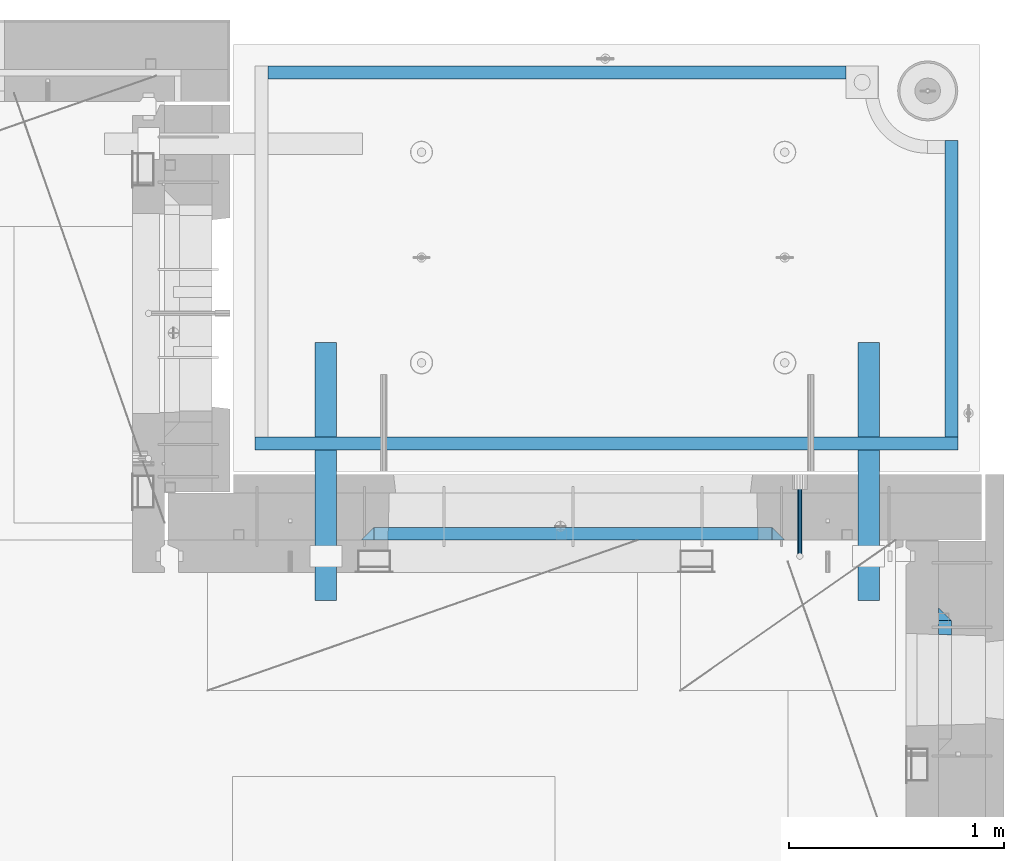
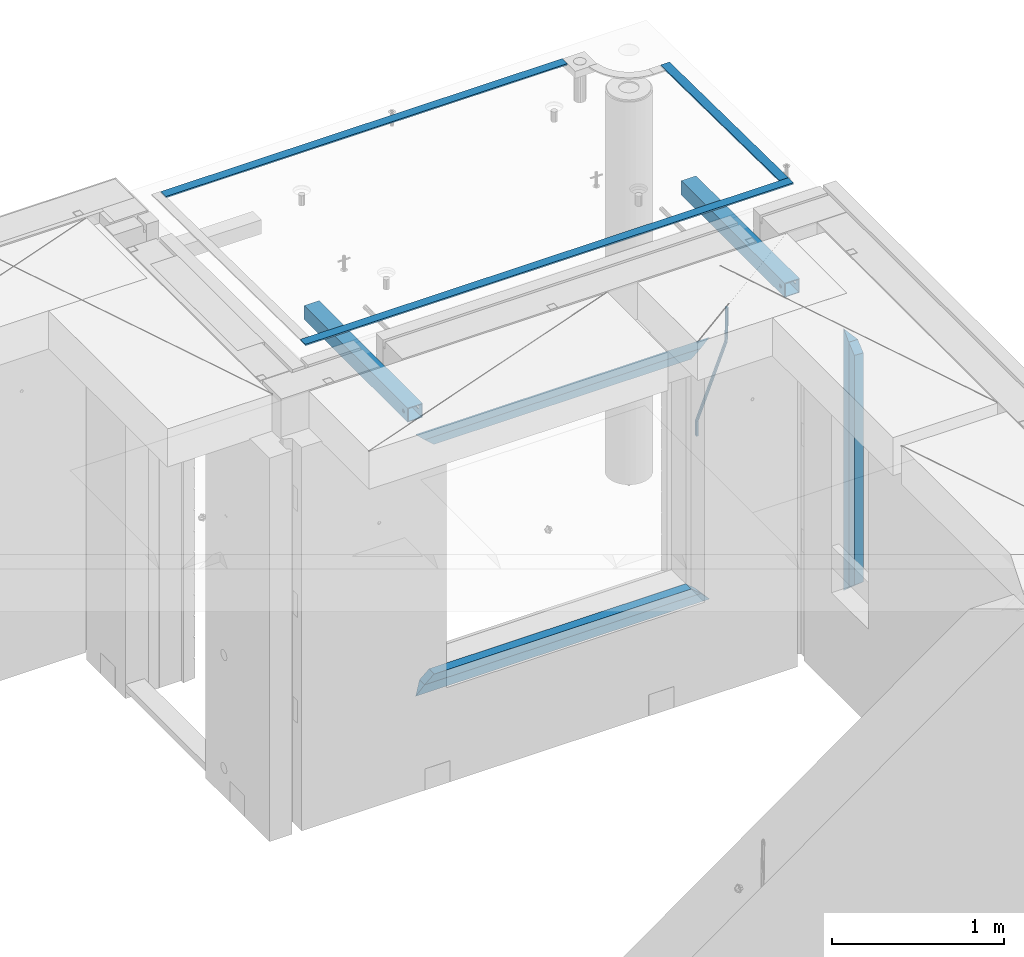
# One storey, part 128 of 334: 12 beams, 5 elements without a shape of their own.
"""IFC2X3 building model written with IfcOpenShell, lengths in millimetres."""

from ifc_helpers import new_model, si_unit, frame, origin_with_axes, place, context, subcontext, project, spatial, faceted_brep, material, type_object, element, aggregate, save


model = new_model("IFC2X3")

# Units and contexts
model_context = context("Model", 3, precision=1e-05, world=origin_with_axes())
body_context = subcontext(model_context, "Body", "Model", "MODEL_VIEW")
ifc_project = project(units=[si_unit("LENGTHUNIT", "METRE", prefix="MILLI"), si_unit("AREAUNIT", "SQUARE_METRE"), si_unit("VOLUMEUNIT", "CUBIC_METRE"), si_unit("MASSUNIT", "GRAM", prefix="KILO"), si_unit("TIMEUNIT", "SECOND"), si_unit("PLANEANGLEUNIT", "RADIAN"), si_unit("SOLIDANGLEUNIT", "STERADIAN"), si_unit("THERMODYNAMICTEMPERATUREUNIT", "DEGREE_CELSIUS"), si_unit("LUMINOUSINTENSITYUNIT", "LUMEN")], contexts=[model_context])

# Site, building, storey
site_placement = place(None, origin_with_axes())
site = spatial("IfcSite", under=ifc_project, at=site_placement, CompositionType="ELEMENT")
building_placement = place(site_placement, origin_with_axes())
building = spatial("IfcBuilding", under=site, at=building_placement, CompositionType="ELEMENT")
storey_placement = place(building_placement, origin_with_axes())
storey = spatial("IfcBuildingStorey", under=building, at=storey_placement, Name="3", CompositionType="ELEMENT", Elevation=0.0)

# Assembly, beam
assembly_1_placement = place(storey_placement, origin_with_axes())
assembly_1 = element("IfcElementAssembly", 1, at=assembly_1_placement, inside=storey, AssemblyPlace="NOTDEFINED", PredefinedType="REINFORCEMENT_UNIT")
ifc_material_1 = material()
beam_type_1 = type_object("IfcBeamType", Name="D20", PredefinedType="NOTDEFINED")
beam_1_placement = place(assembly_1_placement, frame((34415.0000001015, 20504.9951872346, 90407.5), z_axis=(0.000415599999849905, 0.999999913638203, 4.76000000899737e-07), x_axis=(0.0, 0.0, -1.0)))
beam_1 = element("IfcBeam", 2, at=beam_1_placement, type_object=beam_type_1, material=ifc_material_1, Name="JM20", ObjectType="D20", context=body_context, shape_type="Brep", body=[
    faceted_brep([(-0.00060564729210455, -9.99999998165731, 0.0), (-0.000428079845733009, -7.07106779890455, -7.07106781186667), (119.575515501536, -7.07830994756296, -7.07106481604933), (119.575337932896, -10.0072421307195, -3.43332612828817e-06), (0.0, 0.0, -10.0), (119.575943836026, -0.00724214867295814, -9.99999700418266), (0.00042843479604926, 7.07106779888636, -7.07106781186303), (119.57637202373, 7.06382565022977, -7.07106481604933), (0.00060564729210455, 9.99999998166459, 3.63797880709171e-12), (119.576549238118, 9.99275783300072, 2.99581552098971e-06), (0.000428079845733009, 7.07106779890819, 7.07106781186667), (119.576371669405, 7.06382565024978, 7.07107080768037), (0.0, 0.0, 10.0), (119.57594333493, -0.00724214864203532, 10.0000029958155), (-0.000428434810601175, -7.07106779888272, 7.07106781186667), (119.575515147211, -7.07830994754295, 7.07107080768037), (123.00654325854, -7.07836650239551, -6.96786008391246), (122.581588830741, -10.007295666459, 0.0904344953341933), (123.182419066041, -0.00729994480025198, -9.89151006310021), (123.006190977103, 7.06376911688858, -6.96788735351402), (122.581091016109, 9.99270432680532, 0.0903895128230943), (122.156136974867, 7.06377516229986, 7.14867767459873), (121.980261167351, -0.00729139528993983, 10.0723276537792), (122.156489256289, -7.07836045697513, 7.14870494419847), (237.077376207715, -7.07551629289992, -0.0988779924864502), (236.652422053201, -10.0044409119728, 6.95941204931296), (237.253252288647, -0.0044516184279928, -3.02253250974718), (237.077024472936, 7.06661932641327, -0.0989143382521434), (236.651924624995, 9.99555908263574, 6.95936064834314), (236.226970470365, 7.06663446442326, 14.0176506898479), (236.051094389448, -0.0044302100486675, 16.9413052071086), (236.227322205144, -7.07550115488812, 14.0176870356117), (256.715938387759, -7.07353516174771, 4.66794781703175), (253.858321224223, -10.0027051854922, 11.1357628166734), (257.898622435067, -0.00236892073007766, 1.98867362452802), (256.713573090979, 7.0686002544353, 4.66742272414376), (253.85497618909, 9.99729452004976, 11.1350202234971), (250.997359025234, 7.06812449537756, 17.6028352234607), (249.814674977912, -0.00304174564189452, 20.2821094159572), (250.999724322028, -7.07401092080545, 17.6033603163596), (1009.84102825288, -6.93521658215468, 337.477148757798), (1006.98341108896, -9.86438660663771, 343.944963757851), (1011.02371230032, 0.135949658781101, 334.7978745651), (1009.83866295629, 7.20691883402651, 337.476623664521), (1006.98006605446, 10.1356130998429, 343.944221163818), (1004.12244889054, 7.2064430753635, 350.412036163872), (1002.9397648431, 0.135276834424076, 353.091310356571), (1004.12481418712, -6.93569234081951, 350.412561257146), (1010.86335274603, -6.9350288225487, 337.928918327354), (1009.37086865908, -9.86394812736762, 344.999991477531), (1011.48104818776, 0.136033652863262, 334.999973251377), (1010.86211737194, 7.20710680115553, 337.928892551665), (1009.36912157628, 10.1360518725905, 344.9999550252), (1007.87663748935, 7.2071325677698, 352.071028175378), (1007.2589420476, 0.13607009235966, 354.999973251352), (1007.87787286344, -6.93500305593261, 352.071053951067), (1011.98104820926, -6.93502881915083, 337.92891832735), (1011.98104821818, -9.86394811943501, 344.999991477524), (1011.98104818776, 0.136033654382118, 334.999973251375), (1011.98104816627, 7.20710680455704, 337.928892551661), (1011.98104815738, 10.1360518805304, 344.999955025194), (1011.98104816629, 7.20713258024625, 352.071028175369), (1011.98104818778, 0.136070106711486, 354.999973251342), (1011.98104820927, -6.9350030434598, 352.071053951058), (1117.50000002154, -6.93502849844299, 337.928918327156), (1117.50000003044, -9.86394779872717, 344.999991477331), (1117.50000000004, 0.136033975091777, 334.999973251181), (1117.49999997855, 7.20710712526488, 337.928892551467), (1117.49999996964, 10.1360522012383, 344.999955025), (1117.49999997857, 7.20713290095409, 352.071028175174), (1117.50000000006, 0.136070427419327, 354.999973251148), (1117.50000002155, -6.93500272275196, 352.071053950864)], [[[0, 1, 2, 3]], [[1, 4, 5, 2]], [[4, 6, 7, 5]], [[6, 8, 9, 7]], [[8, 10, 11, 9]], [[10, 12, 13, 11]], [[12, 14, 15, 13]], [[14, 0, 3, 15]], [[14, 12, 10, 8, 6, 4, 1, 0]], [[3, 2, 16, 17]], [[2, 5, 18, 16]], [[5, 7, 19, 18]], [[7, 9, 20, 19]], [[9, 11, 21, 20]], [[11, 13, 22, 21]], [[13, 15, 23, 22]], [[15, 3, 17, 23]], [[17, 16, 24, 25]], [[16, 18, 26, 24]], [[18, 19, 27, 26]], [[19, 20, 28, 27]], [[20, 21, 29, 28]], [[21, 22, 30, 29]], [[22, 23, 31, 30]], [[23, 17, 25, 31]], [[25, 24, 32, 33]], [[24, 26, 34, 32]], [[26, 27, 35, 34]], [[27, 28, 36, 35]], [[28, 29, 37, 36]], [[29, 30, 38, 37]], [[30, 31, 39, 38]], [[31, 25, 33, 39]], [[33, 32, 40, 41]], [[32, 34, 42, 40]], [[34, 35, 43, 42]], [[35, 36, 44, 43]], [[36, 37, 45, 44]], [[37, 38, 46, 45]], [[38, 39, 47, 46]], [[39, 33, 41, 47]], [[41, 40, 48, 49]], [[40, 42, 50, 48]], [[42, 43, 51, 50]], [[43, 44, 52, 51]], [[44, 45, 53, 52]], [[45, 46, 54, 53]], [[46, 47, 55, 54]], [[47, 41, 49, 55]], [[49, 48, 56, 57]], [[48, 50, 58, 56]], [[50, 51, 59, 58]], [[51, 52, 60, 59]], [[52, 53, 61, 60]], [[53, 54, 62, 61]], [[54, 55, 63, 62]], [[55, 49, 57, 63]], [[57, 56, 64, 65]], [[56, 58, 66, 64]], [[58, 59, 67, 66]], [[59, 60, 68, 67]], [[60, 61, 69, 68]], [[61, 62, 70, 69]], [[62, 63, 71, 70]], [[63, 57, 65, 71]], [[66, 67, 68, 69, 70, 71, 65, 64]]]),
])

# Assemblies, beams
assembly_2_placement = place(storey_placement, origin_with_axes())
assembly_2 = element("IfcElementAssembly", 3, at=assembly_2_placement, inside=storey, AssemblyPlace="NOTDEFINED", PredefinedType="REINFORCEMENT_UNIT")
assembly_3_placement = place(assembly_2_placement, origin_with_axes())
assembly_3 = element("IfcElementAssembly", 4, at=assembly_3_placement, AssemblyPlace="NOTDEFINED", PredefinedType="NOTDEFINED")
ifc_material_2 = material(Name="Undefined/350")
beam_type_2 = type_object("IfcBeamType", Name="100X100X5", PredefinedType="NOTDEFINED")
beam_2_placement = place(assembly_3_placement, frame((34735.0001432011, 21500.0034426031, 90555.0), z_axis=(0.0, 0.0, 1.0), x_axis=(-2.2242999997242e-05, -0.999999999752625, 0.0)))
beam_2 = element("IfcBeam", 5, at=beam_2_placement, type_object=beam_type_2, material=ifc_material_2, ObjectType="100X100X5", context=body_context, shape_type="Brep", body=[
    faceted_brep([(1143.75108023171, 44.9999999999982, -10.8253175473074), (1143.75107855316, 50.0255964196231, -10.8253175473074), (1139.17576100585, 50.0255948914664, -6.25), (1139.1757626844, 44.9999999999982, -6.25), (1150.00108023171, 44.9999999999982, -12.5), (1150.00107855316, 50.0255985071226, -12.5), (1156.2510802317, 44.9999999999982, -10.8253175473074), (1156.25107855315, 50.0256005946221, -10.8253175473074), (1160.82639777901, 44.9999999999982, -6.25), (1160.82639610046, 50.0256021227788, -6.25), (1162.50108023171, 44.9999999999982, 0.0), (1162.50107855316, 50.0256026821226, 0.0), (1160.82639777901, 44.9999999999982, 6.25), (1160.82639610046, 50.0256021227788, 6.25), (1156.2510802317, 44.9999999999982, 10.8253175473074), (1156.25107855315, 50.0256005946221, 10.8253175473074), (1150.00108023171, 44.9999999999982, 12.5), (1150.00107855316, 50.0255985071226, 12.5), (1143.75108023171, 44.9999999999982, 10.8253175473074), (1143.75107855316, 50.0255964196231, 10.8253175473074), (1139.1757626844, 44.9999999999982, 6.25), (1139.17576100585, 50.0255948914664, 6.25), (1137.5010802317, 44.9999999999982, 0.0), (1137.50107855316, 50.0255943321226, 0.0), (1143.75111195316, -49.9744035792783, -10.8253175473074), (1143.75111029171, -44.9999999999991, -10.8253175473074), (1139.1757927444, -44.9999999999991, -6.25), (1139.17579440585, -49.9744051074349, -6.25), (1150.00111195316, -49.9744014917787, -12.5), (1150.00111029171, -44.9999999999991, -12.5), (1156.25111195316, -49.9743994042774, -10.8253175473074), (1156.25111029171, -44.9999999999991, -10.8253175473074), (1160.82642950046, -49.9743978761207, -6.25), (1160.82642783901, -44.9999999999991, -6.25), (1162.50111195316, -49.9743973167779, 0.0), (1162.50111029171, -44.9999999999991, 0.0), (1160.82642950046, -49.9743978761207, 6.25), (1160.82642783901, -44.9999999999991, 6.25), (1156.25111195316, -49.9743994042774, 10.8253175473074), (1156.25111029171, -44.9999999999991, 10.8253175473074), (1150.00111195316, -49.9744014917787, 12.5), (1150.00111029171, -44.9999999999991, 12.5), (1143.75111195316, -49.9744035792783, 10.8253175473074), (1143.75111029171, -44.9999999999991, 10.8253175473074), (1139.17579440585, -49.9744051074349, 6.25), (1139.1757927444, -44.9999999999991, 6.25), (1137.50111195316, -49.9744056667778, 0.0), (1137.50111029171, -44.9999999999991, 0.0), (1.81898940354586e-12, -50.0000000000009, -50.0), (1.81898940354586e-12, 49.9999999999991, -50.0), (1200.00449189278, 49.9999999999982, -50.0), (1200.00449189278, -50.0000000000009, -50.0), (1.81898940354586e-12, 49.9999999999991, 50.0), (1.81898940354586e-12, -50.0000000000009, 50.0), (1200.00449189278, -50.0000000000009, 50.0), (1200.00449189278, 49.9999999999982, 50.0), (0.0, 44.9999999999991, 45.0), (1.81898940354586e-12, -45.0000000000009, 45.0), (1.81898940354586e-12, -45.0000000000009, -45.0), (0.0, 44.9999999999991, -45.0), (1200.00449189278, 44.9999999999982, -45.0), (1200.00449189278, 44.9999999999982, 45.0), (1200.00449189278, -45.0000000000009, 45.0), (1200.00449189278, -45.0000000000009, -45.0)], [[[0, 1, 2, 3]], [[4, 5, 1, 0]], [[6, 7, 5, 4]], [[8, 9, 7, 6]], [[10, 11, 9, 8]], [[12, 13, 11, 10]], [[14, 15, 13, 12]], [[16, 17, 15, 14]], [[18, 19, 17, 16]], [[20, 21, 19, 18]], [[22, 23, 21, 20]], [[3, 2, 23, 22]], [[24, 25, 26, 27]], [[28, 29, 25, 24]], [[30, 31, 29, 28]], [[32, 33, 31, 30]], [[34, 35, 33, 32]], [[36, 37, 35, 34]], [[38, 39, 37, 36]], [[40, 41, 39, 38]], [[42, 43, 41, 40]], [[44, 45, 43, 42]], [[46, 47, 45, 44]], [[27, 26, 47, 46]], [[48, 49, 50, 51]], [[52, 53, 54, 55]], [[49, 52, 55, 50], [15, 17, 19, 21, 23, 2, 1, 5, 7, 9, 11, 13]], [[48, 53, 52, 49], [56, 57, 58, 59]], [[56, 59, 60, 61], [6, 4, 0, 3, 22, 20, 18, 16, 14, 12, 10, 8]], [[57, 56, 61, 62]], [[58, 57, 62, 63], [39, 41, 43, 45, 47, 26, 25, 29, 31, 33, 35, 37]], [[59, 58, 63, 60]], [[54, 51, 50, 55], [62, 61, 60, 63]], [[53, 48, 51, 54], [30, 28, 24, 27, 46, 44, 42, 40, 38, 36, 34, 32]]]),
])
aggregate(assembly_3, [beam_2])
assembly_4_placement = place(assembly_2_placement, origin_with_axes())
assembly_4 = element("IfcElementAssembly", 6, at=assembly_4_placement, AssemblyPlace="NOTDEFINED", PredefinedType="NOTDEFINED")
beam_3_placement = place(assembly_4_placement, frame((32210.0001432011, 21500.0034426031, 90555.0), z_axis=(0.0, 0.0, 1.0), x_axis=(-2.2242999997242e-05, -0.999999999752625, 0.0)))
beam_3 = element("IfcBeam", 7, at=beam_3_placement, type_object=beam_type_2, material=ifc_material_2, ObjectType="100X100X5", context=body_context, shape_type="Brep", body=[
    faceted_brep([(1143.75108023171, 44.9999999999982, -10.8253175473074), (1143.75107855316, 50.0255964196231, -10.8253175473074), (1139.17576100585, 50.0255948914664, -6.25), (1139.1757626844, 44.9999999999982, -6.25), (1150.00108023171, 44.9999999999982, -12.5), (1150.00107855316, 50.0255985071226, -12.5), (1156.2510802317, 44.9999999999982, -10.8253175473074), (1156.25107855315, 50.0256005946221, -10.8253175473074), (1160.82639777901, 44.9999999999982, -6.25), (1160.82639610046, 50.0256021227788, -6.25), (1162.50108023171, 44.9999999999982, 0.0), (1162.50107855316, 50.0256026821226, 0.0), (1160.82639777901, 44.9999999999982, 6.25), (1160.82639610046, 50.0256021227788, 6.25), (1156.2510802317, 44.9999999999982, 10.8253175473074), (1156.25107855315, 50.0256005946221, 10.8253175473074), (1150.00108023171, 44.9999999999982, 12.5), (1150.00107855316, 50.0255985071226, 12.5), (1143.75108023171, 44.9999999999982, 10.8253175473074), (1143.75107855316, 50.0255964196231, 10.8253175473074), (1139.1757626844, 44.9999999999982, 6.25), (1139.17576100585, 50.0255948914664, 6.25), (1137.5010802317, 44.9999999999982, 0.0), (1137.50107855316, 50.0255943321226, 0.0), (1143.75111195316, -49.9744035792783, -10.8253175473074), (1143.75111029171, -44.9999999999991, -10.8253175473074), (1139.1757927444, -44.9999999999991, -6.25), (1139.17579440585, -49.9744051074349, -6.25), (1150.00111195316, -49.9744014917787, -12.5), (1150.00111029171, -44.9999999999991, -12.5), (1156.25111195316, -49.9743994042774, -10.8253175473074), (1156.25111029171, -44.9999999999991, -10.8253175473074), (1160.82642950046, -49.9743978761207, -6.25), (1160.82642783901, -44.9999999999991, -6.25), (1162.50111195316, -49.9743973167779, 0.0), (1162.50111029171, -44.9999999999991, 0.0), (1160.82642950046, -49.9743978761207, 6.25), (1160.82642783901, -44.9999999999991, 6.25), (1156.25111195316, -49.9743994042774, 10.8253175473074), (1156.25111029171, -44.9999999999991, 10.8253175473074), (1150.00111195316, -49.9744014917787, 12.5), (1150.00111029171, -44.9999999999991, 12.5), (1143.75111195316, -49.9744035792783, 10.8253175473074), (1143.75111029171, -44.9999999999991, 10.8253175473074), (1139.17579440585, -49.9744051074349, 6.25), (1139.1757927444, -44.9999999999991, 6.25), (1137.50111195316, -49.9744056667778, 0.0), (1137.50111029171, -44.9999999999991, 0.0), (1.81898940354586e-12, -50.0000000000009, -50.0), (1.81898940354586e-12, 49.9999999999991, -50.0), (1200.00449189278, 49.9999999999982, -50.0), (1200.00449189278, -50.0000000000009, -50.0), (1.81898940354586e-12, 49.9999999999991, 50.0), (1.81898940354586e-12, -50.0000000000009, 50.0), (1200.00449189278, -50.0000000000009, 50.0), (1200.00449189278, 49.9999999999982, 50.0), (0.0, 44.9999999999991, 45.0), (1.81898940354586e-12, -45.0000000000009, 45.0), (1.81898940354586e-12, -45.0000000000009, -45.0), (0.0, 44.9999999999991, -45.0), (1200.00449189278, 44.9999999999982, -45.0), (1200.00449189278, 44.9999999999982, 45.0), (1200.00449189278, -45.0000000000009, 45.0), (1200.00449189278, -45.0000000000009, -45.0)], [[[0, 1, 2, 3]], [[4, 5, 1, 0]], [[6, 7, 5, 4]], [[8, 9, 7, 6]], [[10, 11, 9, 8]], [[12, 13, 11, 10]], [[14, 15, 13, 12]], [[16, 17, 15, 14]], [[18, 19, 17, 16]], [[20, 21, 19, 18]], [[22, 23, 21, 20]], [[3, 2, 23, 22]], [[24, 25, 26, 27]], [[28, 29, 25, 24]], [[30, 31, 29, 28]], [[32, 33, 31, 30]], [[34, 35, 33, 32]], [[36, 37, 35, 34]], [[38, 39, 37, 36]], [[40, 41, 39, 38]], [[42, 43, 41, 40]], [[44, 45, 43, 42]], [[46, 47, 45, 44]], [[27, 26, 47, 46]], [[48, 49, 50, 51]], [[52, 53, 54, 55]], [[49, 52, 55, 50], [15, 17, 19, 21, 23, 2, 1, 5, 7, 9, 11, 13]], [[48, 53, 52, 49], [56, 57, 58, 59]], [[56, 59, 60, 61], [6, 4, 0, 3, 22, 20, 18, 16, 14, 12, 10, 8]], [[57, 56, 61, 62]], [[58, 57, 62, 63], [39, 41, 43, 45, 47, 26, 25, 29, 31, 33, 35, 37]], [[59, 58, 63, 60]], [[54, 51, 50, 55], [62, 61, 60, 63]], [[53, 48, 51, 54], [30, 28, 24, 27, 46, 44, 42, 40, 38, 36, 34, 32]]]),
])
aggregate(assembly_4, [beam_3])
ifc_material_3 = material(Name="CONCRETE/Concrete_Undefined")
beam_type_3 = type_object("IfcBeamType", PredefinedType="NOTDEFINED")
beam_4_placement = place(assembly_2_placement, frame((31939.9962088653, 22755.0460044164, 90704.8214945676), z_axis=(-6.06120000110142e-05, 1.00000033869885e-09, 0.999999998163093), x_axis=(0.999999998046552, -1.52670000006885e-05, 6.06120000021532e-05)))
beam_4 = element("IfcBeam", 8, at=beam_4_placement, type_object=beam_type_3, material=ifc_material_3, context=body_context, shape_type="Brep", body=[
    faceted_brep([(2.5465851649642e-11, 29.9999999999982, -4.99999999998545), (-2.91038304567337e-11, 29.9999999999982, 5.0), (2689.99575395095, 29.9999999999964, 5.0), (2689.99575395095, 30.0000000000036, -4.99999999998545), (-2.5465851649642e-11, -30.0000000000018, 5.0), (2689.99575395095, -30.0000000000036, 5.00000000001455), (2.72848410531878e-11, -30.0000000000018, -4.99999999998545), (2689.99575395095, -29.9999999999964, -4.99999999998545)], [[[0, 1, 2, 3]], [[1, 4, 5, 2]], [[4, 6, 7, 5]], [[6, 0, 3, 7]], [[5, 7, 3, 2]], [[6, 4, 1, 0]]]),
])
beam_5_placement = place(assembly_2_placement, frame((35120.0586113047, 21059.9283388168, 90725.6638339053), z_axis=(-5.46000002942176e-07, 0.0130421150000144, 0.999914948001093), x_axis=(-4.18520000064741e-05, 0.999914947125351, -0.0130421150016393)))
beam_5 = element("IfcBeam", 9, at=beam_5_placement, type_object=beam_type_3, material=ifc_material_3, context=body_context, shape_type="Brep", body=[
    faceted_brep([(2.5465851649642e-11, 29.9999999999982, -4.99999999998545), (-2.91038304567337e-11, 29.9999999999982, 5.0), (1380.14316164461, 30.0, 5.00000000001455), (1380.1431616447, 29.9999999999927, -5.0), (-2.5465851649642e-11, -30.0000000000018, 5.0), (1380.14316164461, -30.0, 5.00000000001455), (2.72848410531878e-11, -30.0000000000018, -4.99999999998545), (1380.1431616447, -30.0, -5.0)], [[[0, 1, 2, 3]], [[1, 4, 5, 2]], [[4, 6, 7, 5]], [[6, 0, 3, 7]], [[5, 7, 3, 2]], [[6, 4, 1, 0]]]),
])
beam_6_placement = place(assembly_2_placement, frame((31879.9986204165, 21030.068155681, 90725.2788443041), z_axis=(-0.000117617000009658, 3.00000101585662e-09, 0.999999993083121), x_axis=(0.999999992839137, -2.20899999960382e-05, 0.000117616999982089)))
beam_6 = element("IfcBeam", 10, at=beam_6_placement, type_object=beam_type_3, material=ifc_material_3, context=body_context, shape_type="Brep", body=[
    faceted_brep([(2.5465851649642e-11, 29.9999999999982, -4.99999999998545), (-2.91038304567337e-11, 29.9999999999982, 5.0), (3270.06002088557, 30.0, 5.0), (3270.06002088557, 30.0000000000036, -5.0), (-2.5465851649642e-11, -30.0000000000018, 5.0), (3270.06002088557, -30.0, 5.0), (2.72848410531878e-11, -30.0000000000018, -4.99999999998545), (3270.06002088558, -29.9999999999964, -5.0)], [[[0, 1, 2, 3]], [[1, 4, 5, 2]], [[4, 6, 7, 5]], [[6, 0, 3, 7]], [[5, 7, 3, 2]], [[6, 4, 1, 0]]]),
])
aggregate(assembly_2, [beam_4, assembly_3, beam_5, beam_6, assembly_4])

# Beam
ifc_material_4 = material(Name="CONCRETE/C25/30")
beam_type_4 = type_object("IfcBeamType", PredefinedType="NOTDEFINED")
beam_7_placement = place(assembly_1_placement, frame((34345.0010086818, 20609.9951872276, 90145.0), z_axis=(0.0, 0.0, -1.0), x_axis=(-1.0, 3.00000001838171e-08, 0.0)))
beam_7 = element("IfcBeam", 11, at=beam_7_placement, type_object=beam_type_4, material=ifc_material_4, Name="SK", context=body_context, shape_type="Brep", body=[
    faceted_brep([(60.0000000000073, 30.0, 30.0), (0.0, -30.0, -30.0), (60.0000000000073, -30.0, 30.0), (1910.00076293945, 30.0, 30.0), (1970.00076293945, -30.0, -30.0), (1910.00076293945, -30.0, 30.0)], [[[0, 1, 2]], [[1, 0, 3, 4]], [[2, 1, 4, 5]], [[0, 2, 5, 3]], [[4, 3, 5]]]),
])

beam_8_placement = place(assembly_1_placement, frame((34285.0010086818, 20609.9951872276, 90085.0), z_axis=(0.0, 0.0, -1.0), x_axis=(-1.0, 3.00000001838171e-08, 0.0)))
beam_8 = element("IfcBeam", 12, at=beam_8_placement, type_object=beam_type_4, material=ifc_material_4, Name="SK", context=body_context, shape_type="Brep", body=[
    faceted_brep([(64.0548169935064, -30.0, 24.9041288395529), (65.6764386151262, 30.0, 26.294090229203), (0.0, 30.0, -30.0), (0.0, -30.0, -30.0), (64.0548169935064, -30.0, 24.0540540540533), (65.6764386151262, 30.0, 25.6756756756804), (1785.9467088854, -30.0, 24.0540540540533), (1784.32508726378, 30.0, 25.6756756756804), (1784.32508726378, 30.0, 26.2934362810774), (1850.00076293945, 30.0, -30.0), (1850.00076293945, -30.0, -30.0), (1785.9467088854, -30.0, 24.9034748914128)], [[[0, 1, 2, 3]], [[4, 5, 1, 0]], [[6, 7, 5, 4]], [[2, 1, 5, 7, 8, 9]], [[3, 2, 9, 10]], [[6, 4, 0, 3, 10, 11]], [[7, 6, 11, 8]], [[10, 9, 8, 11]]]),
])

beam_9_placement = place(assembly_1_placement, frame((32375.0002457424, 20609.9951872276, 88350.0), z_axis=(0.0, 0.0, 1.0), x_axis=(1.0, 0.0, 0.0)))
beam_9 = element("IfcBeam", 13, at=beam_9_placement, type_object=beam_type_4, material=ifc_material_4, Name="SK", context=body_context, shape_type="Brep", body=[
    faceted_brep([(1970.00076293945, -30.0, -30.0), (1910.00076293945, 30.0, 30.0), (1910.00076293945, -30.0, 30.0), (60.0000000000073, 30.0, 30.0), (60.0000000000073, -30.0, 30.0), (0.0, -30.0, -30.0)], [[[0, 1, 2]], [[3, 4, 2, 1]], [[4, 5, 0, 2]], [[5, 3, 1, 0]], [[3, 5, 4]]]),
])

beam_10_placement = place(assembly_1_placement, frame((32435.0002457424, 20609.9951872276, 88410.0), z_axis=(0.0, 0.0, 1.0), x_axis=(1.0, 0.0, 0.0)))
beam_10 = element("IfcBeam", 14, at=beam_10_placement, type_object=beam_type_4, material=ifc_material_4, Name="SK", context=body_context, shape_type="Brep", body=[
    faceted_brep([(1785.94594594595, -30.0, 24.9041288395238), (1850.00076293945, -30.0, -30.0), (1850.00076293945, 30.0, -30.0), (1784.32432432433, 30.0, 26.2940902291739), (1784.32432432433, 30.0, 25.6756756756804), (1785.94594594595, -30.0, 24.0540540540533), (65.6756756756768, 30.0, 25.6756756756804), (64.0540540540533, -30.0, 24.0540540540533), (65.6756756756768, 30.0, 26.293436281092), (64.0540540540533, -30.0, 24.9034748914419), (0.0, -30.0, -30.0), (0.0, 30.0, -30.0)], [[[0, 1, 2, 3]], [[4, 5, 0, 3]], [[5, 4, 6, 7]], [[7, 6, 8, 9]], [[1, 0, 5, 7, 9, 10]], [[10, 11, 2, 1]], [[6, 4, 3, 2, 11, 8]], [[10, 9, 8, 11]]]),
])

aggregate(assembly_1, [beam_1, beam_7, beam_8, beam_9, beam_10])

# Assembly, beams
assembly_5_placement = place(storey_placement, origin_with_axes())
assembly_5 = element("IfcElementAssembly", 15, at=assembly_5_placement, inside=storey, AssemblyPlace="NOTDEFINED", PredefinedType="REINFORCEMENT_UNIT")
beam_11_placement = place(assembly_5_placement, frame((35090.0, 20234.9999664753, 90175.0), z_axis=(0.0, -1.0, 0.0), x_axis=(0.0, 0.0, -1.0)))
beam_11 = element("IfcBeam", 16, at=beam_11_placement, type_object=beam_type_4, material=ifc_material_4, Name="SK", context=body_context, shape_type="Brep", body=[
    faceted_brep([(60.0000000000073, 30.0, 30.0), (0.0, -30.0, -30.0), (60.0000000000073, -30.0, 30.0), (1795.00000000001, 30.0, 30.0), (1855.0, -30.0, -30.0), (1795.00000000001, -30.0, 30.0)], [[[0, 1, 2]], [[3, 4, 1, 0]], [[4, 5, 2, 1]], [[5, 3, 0, 2]], [[5, 4, 3]]]),
])
beam_type_5 = type_object("IfcBeamType", PredefinedType="NOTDEFINED")
beam_12_placement = place(assembly_5_placement, frame((35090.0, 20169.9999664753, 90115.0), z_axis=(0.0, -1.0, 0.0), x_axis=(0.0, 0.0, -1.0)))
beam_12 = element("IfcBeam", 17, at=beam_12_placement, type_object=beam_type_5, material=ifc_material_4, Name="SK", context=body_context, shape_type="Brep", body=[
    faceted_brep([(0.0, -30.0, -35.0), (54.9034748914273, -30.0, 29.0540540540533), (56.2934362811066, 30.0, 30.6756756756768), (0.0, 30.0, -35.0), (1735.0, 30.0, -35.0), (1735.0, -30.0, -35.0), (1680.09652510857, -30.0, 29.0540540540533), (1678.70656371891, 30.0, 30.6756756756768)], [[[0, 1, 2, 3]], [[4, 5, 0, 3]], [[1, 0, 5, 6]], [[2, 1, 6, 7]], [[3, 2, 7, 4]], [[5, 4, 7, 6]]]),
])
aggregate(assembly_5, [beam_11, beam_12])

save(model, "model.ifc")
